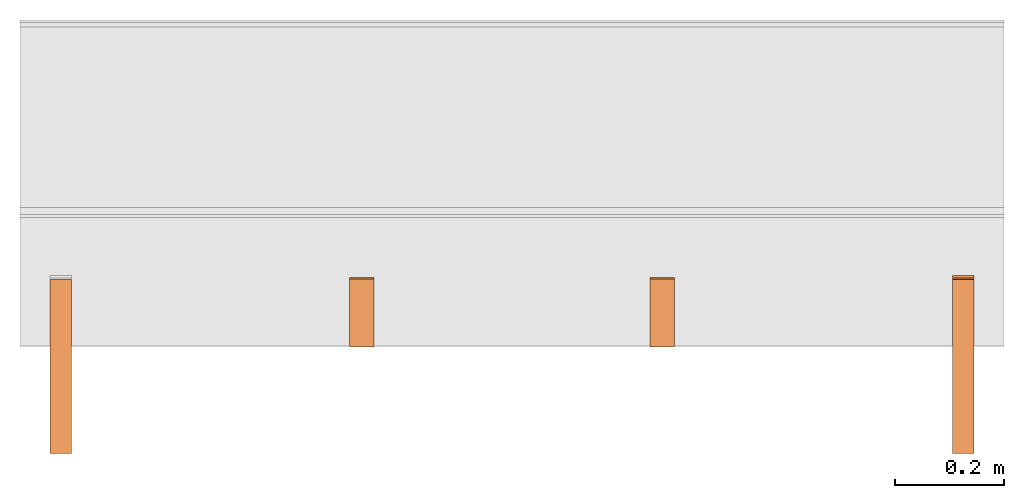
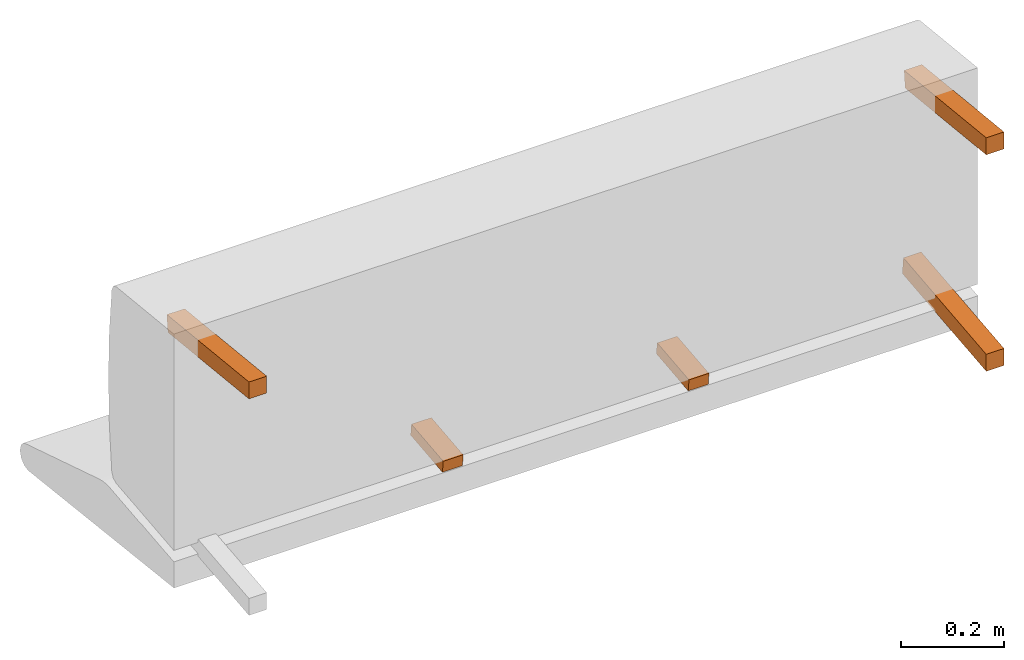
# One storey, part 3 of 3: 5 proxies, 1 element without a shape of its own.
"""IFC2X3 building model written with IfcOpenShell, lengths in metres."""

from ifc_helpers import new_model, si_unit, direction, origin_with_axes, place, context, project, spatial, faceted_brep, source, transform, mapped, element, aggregate, save


model = new_model("IFC2X3")

# Units and contexts
model_context = context("Model", 3, precision=1e-06, world=origin_with_axes(), true_north=direction((0.0, 1.0, 0.0)))
ifc_project = project(units=[si_unit("LENGTHUNIT", "METRE"), si_unit("AREAUNIT", "SQUARE_METRE"), si_unit("VOLUMEUNIT", "CUBIC_METRE")], contexts=[model_context])

# Site, building, storey
site_placement = place(None, origin_with_axes())
site = spatial("IfcSite", under=ifc_project, at=site_placement, CompositionType="ELEMENT")
building_placement = place(site_placement, origin_with_axes())
building = spatial("IfcBuilding", under=site, at=building_placement, Name="Default Building", CompositionType="ELEMENT")
storey_placement = place(building_placement, origin_with_axes())
storey = spatial("IfcBuildingStorey", under=building, at=storey_placement, Name="Default Storey", CompositionType="ELEMENT", Elevation=0.0)

# Assembly, proxies
assembly_placement = place(storey_placement, origin_with_axes())
assembly = element("IfcElementAssembly", 1, at=assembly_placement, inside=storey, AssemblyPlace="NOTDEFINED", PredefinedType="NOTDEFINED")
shared_shape_1 = source(origin_with_axes(), model_context, "Body", "Brep", [
    faceted_brep([(-0.8100000023841858, 0.00747277494519949, 0.17069438099861145), (-0.8100000023841858, -0.3086836636066437, 0.203923761844635), (-0.8500000238418579, 0.00747277494519949, 0.17069438099861145), (-0.8500000238418579, 0.00747277494519949, 0.17069438099861145), (-0.8100000023841858, -0.3086836636066437, 0.203923761844635), (-0.8500000238418579, -0.3086836636066437, 0.203923761844635), (-0.8100000023841858, -0.3086836636066437, 0.203923761844635), (-0.8100000023841858, -0.3086836636066437, 0.24414409697055817), (-0.8500000238418579, -0.3086836636066437, 0.203923761844635), (-0.8500000238418579, -0.3086836636066437, 0.203923761844635), (-0.8100000023841858, -0.3086836636066437, 0.24414409697055817), (-0.8500000238418579, -0.3086836636066437, 0.24414409697055817), (-0.8100000023841858, -0.3086836636066437, 0.24414409697055817), (-0.8100000023841858, 0.011653914116322994, 0.21047525107860565), (-0.8500000238418579, -0.3086836636066437, 0.24414409697055817), (-0.8500000238418579, -0.3086836636066437, 0.24414409697055817), (-0.8100000023841858, 0.011653914116322994, 0.21047525107860565), (-0.8500000238418579, 0.011653914116322994, 0.21047525107860565), (-0.8100000023841858, 0.011653914116322994, 0.21047525107860565), (-0.8100000023841858, 0.00747277494519949, 0.17069438099861145), (-0.8500000238418579, 0.011653914116322994, 0.21047525107860565), (-0.8500000238418579, 0.011653914116322994, 0.21047525107860565), (-0.8100000023841858, 0.00747277494519949, 0.17069438099861145), (-0.8500000238418579, 0.00747277494519949, 0.17069438099861145), (-0.8100000023841858, 0.011653914116322994, 0.21047525107860565), (-0.8100000023841858, -0.3086836636066437, 0.24414409697055817), (-0.8100000023841858, 0.00747277494519949, 0.17069438099861145), (-0.8100000023841858, 0.00747277494519949, 0.17069438099861145), (-0.8100000023841858, -0.3086836636066437, 0.24414409697055817), (-0.8100000023841858, -0.3086836636066437, 0.203923761844635), (-0.8500000238418579, -0.3086836636066437, 0.24414409697055817), (-0.8500000238418579, 0.011653914116322994, 0.21047525107860565), (-0.8500000238418579, -0.3086836636066437, 0.203923761844635), (-0.8500000238418579, -0.3086836636066437, 0.203923761844635), (-0.8500000238418579, 0.011653914116322994, 0.21047525107860565), (-0.8500000238418579, 0.00747277494519949, 0.17069438099861145)], [[[0, 1, 2]], [[3, 4, 5]], [[6, 7, 8]], [[9, 10, 11]], [[12, 13, 14]], [[15, 16, 17]], [[18, 19, 20]], [[21, 22, 23]], [[24, 25, 26]], [[27, 28, 29]], [[30, 31, 32]], [[33, 34, 35]]]),
])
proxy_1_placement = place(assembly_placement, origin_with_axes())
proxy_1 = element("IfcBuildingElementProxy", 2, at=proxy_1_placement, Name="3", ObjectType="3", CompositionType="ELEMENT", context=model_context, shape_type="MappedRepresentation", body=[
    mapped(shared_shape_1, transform((0.0, 0.0, 0.0), scale=1.0)),
])
shared_shape_2 = source(origin_with_axes(), model_context, "Body", "Brep", [
    faceted_brep([(0.8500000238418579, 0.00747277494519949, 0.17069438099861145), (0.8500000238418579, -0.3086836636066437, 0.203923761844635), (0.8100000023841858, 0.00747277494519949, 0.17069438099861145), (0.8100000023841858, 0.00747277494519949, 0.17069438099861145), (0.8500000238418579, -0.3086836636066437, 0.203923761844635), (0.8100000023841858, -0.3086836636066437, 0.203923761844635), (0.8500000238418579, -0.3086836636066437, 0.203923761844635), (0.8500000238418579, -0.3086836636066437, 0.24414409697055817), (0.8100000023841858, -0.3086836636066437, 0.203923761844635), (0.8100000023841858, -0.3086836636066437, 0.203923761844635), (0.8500000238418579, -0.3086836636066437, 0.24414409697055817), (0.8100000023841858, -0.3086836636066437, 0.24414409697055817), (0.8500000238418579, -0.3086836636066437, 0.24414409697055817), (0.8500000238418579, 0.011653914116322994, 0.21047525107860565), (0.8100000023841858, -0.3086836636066437, 0.24414409697055817), (0.8100000023841858, -0.3086836636066437, 0.24414409697055817), (0.8500000238418579, 0.011653914116322994, 0.21047525107860565), (0.8100000023841858, 0.011653914116322994, 0.21047525107860565), (0.8500000238418579, 0.011653914116322994, 0.21047525107860565), (0.8500000238418579, 0.00747277494519949, 0.17069438099861145), (0.8100000023841858, 0.011653914116322994, 0.21047525107860565), (0.8100000023841858, 0.011653914116322994, 0.21047525107860565), (0.8500000238418579, 0.00747277494519949, 0.17069438099861145), (0.8100000023841858, 0.00747277494519949, 0.17069438099861145), (0.8500000238418579, 0.011653914116322994, 0.21047525107860565), (0.8500000238418579, -0.3086836636066437, 0.24414409697055817), (0.8500000238418579, 0.00747277494519949, 0.17069438099861145), (0.8500000238418579, 0.00747277494519949, 0.17069438099861145), (0.8500000238418579, -0.3086836636066437, 0.24414409697055817), (0.8500000238418579, -0.3086836636066437, 0.203923761844635), (0.8100000023841858, -0.3086836636066437, 0.24414409697055817), (0.8100000023841858, 0.011653914116322994, 0.21047525107860565), (0.8100000023841858, -0.3086836636066437, 0.203923761844635), (0.8100000023841858, -0.3086836636066437, 0.203923761844635), (0.8100000023841858, 0.011653914116322994, 0.21047525107860565), (0.8100000023841858, 0.00747277494519949, 0.17069438099861145)], [[[0, 1, 2]], [[3, 4, 5]], [[6, 7, 8]], [[9, 10, 11]], [[12, 13, 14]], [[15, 16, 17]], [[18, 19, 20]], [[21, 22, 23]], [[24, 25, 26]], [[27, 28, 29]], [[30, 31, 32]], [[33, 34, 35]]]),
])
proxy_2_placement = place(assembly_placement, origin_with_axes())
proxy_2 = element("IfcBuildingElementProxy", 3, at=proxy_2_placement, Name="4", ObjectType="4", CompositionType="ELEMENT", context=model_context, shape_type="MappedRepresentation", body=[
    mapped(shared_shape_2, transform((0.0, 0.0, 0.0), scale=1.0)),
])
shared_shape_3 = source(origin_with_axes(), model_context, "Body", "Brep", [
    faceted_brep([(0.8500000238418579, -0.3086628317832947, -0.31151315569877625), (0.8500000238418579, -0.3086628317832947, -0.2712928354740143), (0.8100000023841858, -0.3086628317832947, -0.31151315569877625), (0.8100000023841858, -0.3086628317832947, -0.31151315569877625), (0.8500000238418579, -0.3086628317832947, -0.2712928354740143), (0.8100000023841858, -0.3086628317832947, -0.2712928354740143), (0.8500000238418579, -0.3086628317832947, -0.2712928354740143), (0.8500000238418579, 0.014455263502895832, -0.23733174800872803), (0.8100000023841858, -0.3086628317832947, -0.2712928354740143), (0.8100000023841858, -0.3086628317832947, -0.2712928354740143), (0.8500000238418579, 0.014455263502895832, -0.23733174800872803), (0.8100000023841858, 0.014455263502895832, -0.23733174800872803), (0.8500000238418579, 0.014455263502895832, -0.23733174800872803), (0.8500000238418579, 0.018636401742696762, -0.2771126329898834), (0.8100000023841858, 0.014455263502895832, -0.23733174800872803), (0.8100000023841858, 0.014455263502895832, -0.23733174800872803), (0.8500000238418579, 0.018636401742696762, -0.2771126329898834), (0.8100000023841858, 0.018636401742696762, -0.2771126329898834), (0.8500000238418579, 0.018636401742696762, -0.2771126329898834), (0.8500000238418579, -0.3086628317832947, -0.31151315569877625), (0.8100000023841858, 0.018636401742696762, -0.2771126329898834), (0.8100000023841858, 0.018636401742696762, -0.2771126329898834), (0.8500000238418579, -0.3086628317832947, -0.31151315569877625), (0.8100000023841858, -0.3086628317832947, -0.31151315569877625), (0.8500000238418579, 0.018636401742696762, -0.2771126329898834), (0.8500000238418579, 0.014455263502895832, -0.23733174800872803), (0.8500000238418579, -0.3086628317832947, -0.31151315569877625), (0.8500000238418579, -0.3086628317832947, -0.31151315569877625), (0.8500000238418579, 0.014455263502895832, -0.23733174800872803), (0.8500000238418579, -0.3086628317832947, -0.2712928354740143), (0.8100000023841858, 0.014455263502895832, -0.23733174800872803), (0.8100000023841858, 0.018636401742696762, -0.2771126329898834), (0.8100000023841858, -0.3086628317832947, -0.2712928354740143), (0.8100000023841858, -0.3086628317832947, -0.2712928354740143), (0.8100000023841858, 0.018636401742696762, -0.2771126329898834), (0.8100000023841858, -0.3086628317832947, -0.31151315569877625)], [[[0, 1, 2]], [[3, 4, 5]], [[6, 7, 8]], [[9, 10, 11]], [[12, 13, 14]], [[15, 16, 17]], [[18, 19, 20]], [[21, 22, 23]], [[24, 25, 26]], [[27, 28, 29]], [[30, 31, 32]], [[33, 34, 35]]]),
])
proxy_3_placement = place(assembly_placement, origin_with_axes())
proxy_3 = element("IfcBuildingElementProxy", 4, at=proxy_3_placement, Name="5", ObjectType="5", CompositionType="ELEMENT", context=model_context, shape_type="MappedRepresentation", body=[
    mapped(shared_shape_3, transform((0.0, 0.0, 0.0), scale=1.0)),
])
shared_shape_4 = source(origin_with_axes(), model_context, "Body", "Brep", [
    faceted_brep([(-0.2991666793823242, -0.10928957164287567, -0.2845251262187958), (-0.2991666793823242, 0.015025665983557701, -0.27145907282829285), (-0.2541666626930237, -0.10928957164287567, -0.2845251262187958), (-0.2541666626930237, -0.10928957164287567, -0.2845251262187958), (-0.2991666793823242, 0.015025665983557701, -0.27145907282829285), (-0.2541666626930237, 0.015025665983557701, -0.27145907282829285), (-0.2991666793823242, -0.11221636831760406, -0.2566785216331482), (-0.2991666793823242, -0.10928957164287567, -0.2845251262187958), (-0.2541666626930237, -0.11221636831760406, -0.2566785216331482), (-0.2541666626930237, -0.11221636831760406, -0.2566785216331482), (-0.2991666793823242, -0.10928957164287567, -0.2845251262187958), (-0.2541666626930237, -0.10928957164287567, -0.2845251262187958), (-0.2991666793823242, 0.012098868377506733, -0.24361246824264526), (-0.2991666793823242, -0.11221636831760406, -0.2566785216331482), (-0.2541666626930237, 0.012098868377506733, -0.24361246824264526), (-0.2541666626930237, 0.012098868377506733, -0.24361246824264526), (-0.2991666793823242, -0.11221636831760406, -0.2566785216331482), (-0.2541666626930237, -0.11221636831760406, -0.2566785216331482), (-0.2991666793823242, 0.015025665983557701, -0.27145907282829285), (-0.2991666793823242, 0.012098868377506733, -0.24361246824264526), (-0.2541666626930237, 0.015025665983557701, -0.27145907282829285), (-0.2541666626930237, 0.015025665983557701, -0.27145907282829285), (-0.2991666793823242, 0.012098868377506733, -0.24361246824264526), (-0.2541666626930237, 0.012098868377506733, -0.24361246824264526), (-0.2991666793823242, -0.11221636831760406, -0.2566785216331482), (-0.2991666793823242, 0.012098868377506733, -0.24361246824264526), (-0.2991666793823242, -0.10928957164287567, -0.2845251262187958), (-0.2991666793823242, -0.10928957164287567, -0.2845251262187958), (-0.2991666793823242, 0.012098868377506733, -0.24361246824264526), (-0.2991666793823242, 0.015025665983557701, -0.27145907282829285), (-0.2541666626930237, 0.012098868377506733, -0.24361246824264526), (-0.2541666626930237, -0.11221636831760406, -0.2566785216331482), (-0.2541666626930237, 0.015025665983557701, -0.27145907282829285), (-0.2541666626930237, 0.015025665983557701, -0.27145907282829285), (-0.2541666626930237, -0.11221636831760406, -0.2566785216331482), (-0.2541666626930237, -0.10928957164287567, -0.2845251262187958)], [[[0, 1, 2]], [[3, 4, 5]], [[6, 7, 8]], [[9, 10, 11]], [[12, 13, 14]], [[15, 16, 17]], [[18, 19, 20]], [[21, 22, 23]], [[24, 25, 26]], [[27, 28, 29]], [[30, 31, 32]], [[33, 34, 35]]]),
])
proxy_4_placement = place(assembly_placement, origin_with_axes())
proxy_4 = element("IfcBuildingElementProxy", 5, at=proxy_4_placement, Name="8", ObjectType="8", CompositionType="ELEMENT", context=model_context, shape_type="MappedRepresentation", body=[
    mapped(shared_shape_4, transform((0.0, 0.0, 0.0), scale=1.0)),
])
shared_shape_5 = source(origin_with_axes(), model_context, "Body", "Brep", [
    faceted_brep([(0.2541666626930237, -0.10928957164287567, -0.2845251262187958), (0.2541666626930237, 0.015025665983557701, -0.27145907282829285), (0.2991666793823242, -0.10928957164287567, -0.2845251262187958), (0.2991666793823242, -0.10928957164287567, -0.2845251262187958), (0.2541666626930237, 0.015025665983557701, -0.27145907282829285), (0.2991666793823242, 0.015025665983557701, -0.27145907282829285), (0.2541666626930237, -0.11221636831760406, -0.2566785216331482), (0.2541666626930237, -0.10928957164287567, -0.2845251262187958), (0.2991666793823242, -0.11221636831760406, -0.2566785216331482), (0.2991666793823242, -0.11221636831760406, -0.2566785216331482), (0.2541666626930237, -0.10928957164287567, -0.2845251262187958), (0.2991666793823242, -0.10928957164287567, -0.2845251262187958), (0.2541666626930237, 0.012098868377506733, -0.24361246824264526), (0.2541666626930237, -0.11221636831760406, -0.2566785216331482), (0.2991666793823242, 0.012098868377506733, -0.24361246824264526), (0.2991666793823242, 0.012098868377506733, -0.24361246824264526), (0.2541666626930237, -0.11221636831760406, -0.2566785216331482), (0.2991666793823242, -0.11221636831760406, -0.2566785216331482), (0.2541666626930237, 0.015025665983557701, -0.27145907282829285), (0.2541666626930237, 0.012098868377506733, -0.24361246824264526), (0.2991666793823242, 0.015025665983557701, -0.27145907282829285), (0.2991666793823242, 0.015025665983557701, -0.27145907282829285), (0.2541666626930237, 0.012098868377506733, -0.24361246824264526), (0.2991666793823242, 0.012098868377506733, -0.24361246824264526), (0.2541666626930237, -0.11221636831760406, -0.2566785216331482), (0.2541666626930237, 0.012098868377506733, -0.24361246824264526), (0.2541666626930237, -0.10928957164287567, -0.2845251262187958), (0.2541666626930237, -0.10928957164287567, -0.2845251262187958), (0.2541666626930237, 0.012098868377506733, -0.24361246824264526), (0.2541666626930237, 0.015025665983557701, -0.27145907282829285), (0.2991666793823242, 0.012098868377506733, -0.24361246824264526), (0.2991666793823242, -0.11221636831760406, -0.2566785216331482), (0.2991666793823242, 0.015025665983557701, -0.27145907282829285), (0.2991666793823242, 0.015025665983557701, -0.27145907282829285), (0.2991666793823242, -0.11221636831760406, -0.2566785216331482), (0.2991666793823242, -0.10928957164287567, -0.2845251262187958)], [[[0, 1, 2]], [[3, 4, 5]], [[6, 7, 8]], [[9, 10, 11]], [[12, 13, 14]], [[15, 16, 17]], [[18, 19, 20]], [[21, 22, 23]], [[24, 25, 26]], [[27, 28, 29]], [[30, 31, 32]], [[33, 34, 35]]]),
])
proxy_5_placement = place(assembly_placement, origin_with_axes())
proxy_5 = element("IfcBuildingElementProxy", 6, at=proxy_5_placement, Name="9", ObjectType="9", CompositionType="ELEMENT", context=model_context, shape_type="MappedRepresentation", body=[
    mapped(shared_shape_5, transform((0.0, 0.0, 0.0), scale=1.0)),
])
aggregate(assembly, [proxy_1, proxy_2, proxy_3, proxy_4, proxy_5])

save(model, "model.ifc")
